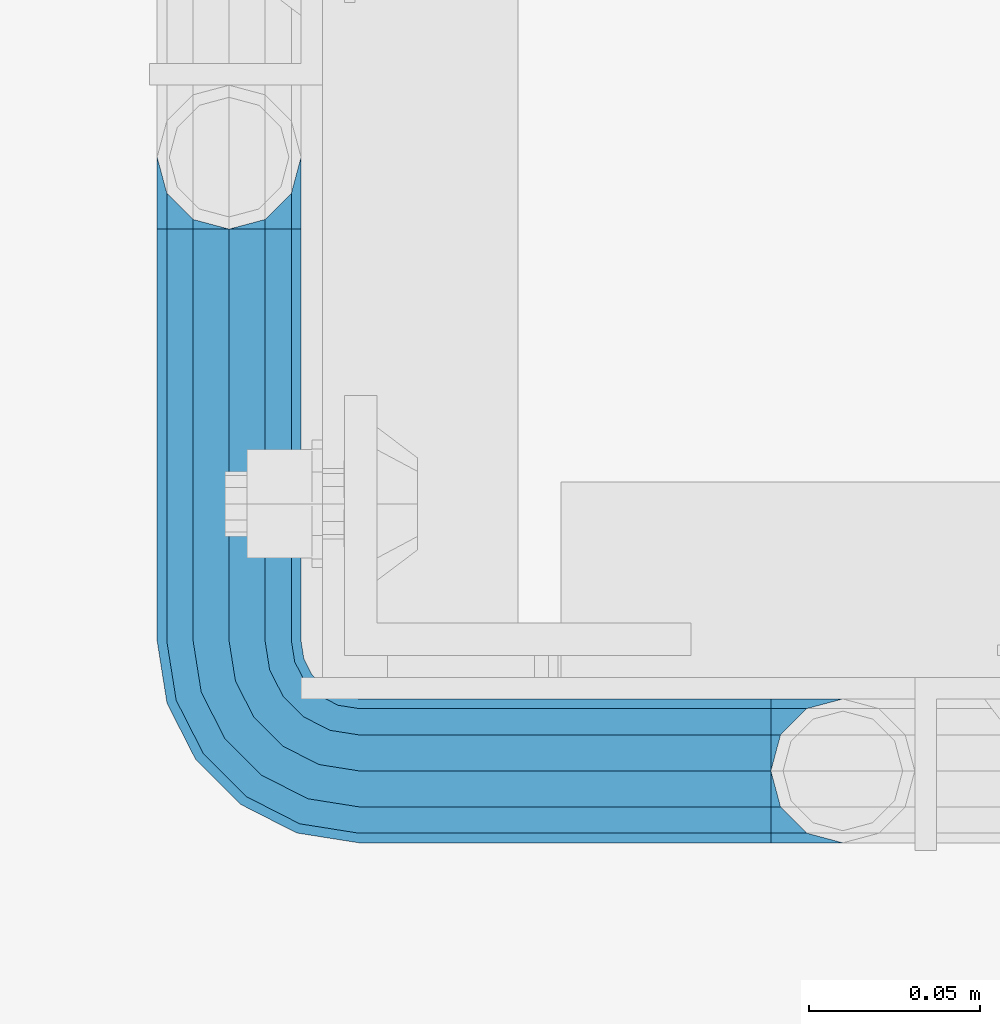
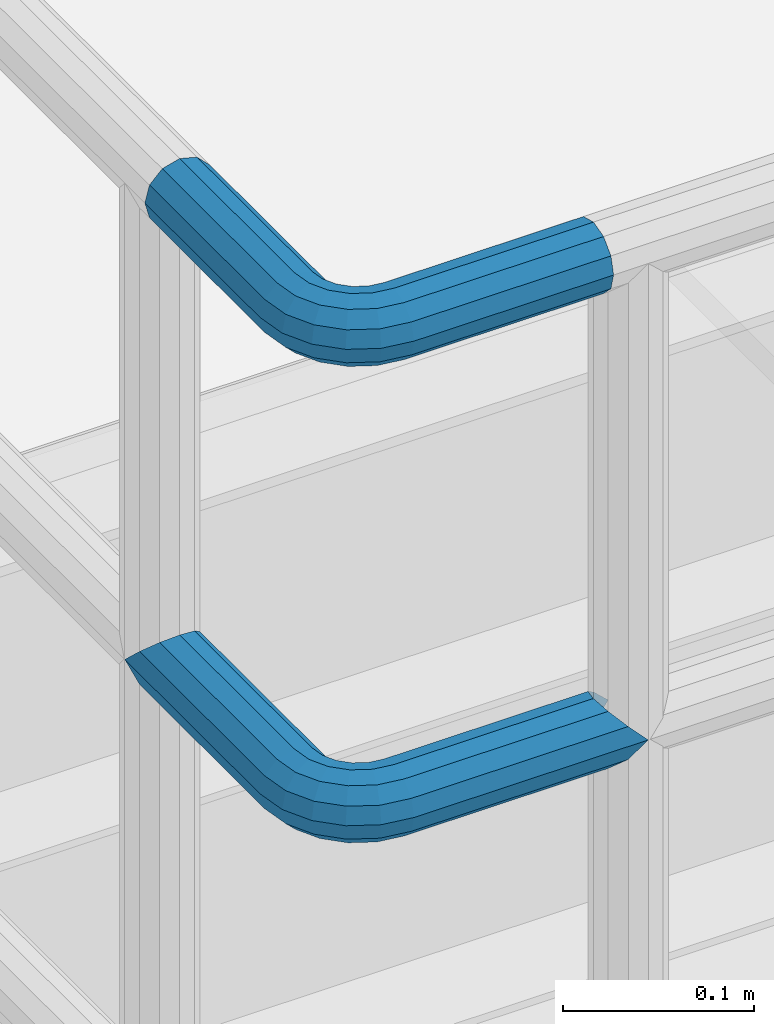
# One storey, part 1108 of 1876: 2 beams, 1 element without a shape of its own.
"""IFC2X3 building model written with IfcOpenShell, lengths in millimetres."""

from ifc_helpers import new_model, si_unit, frame, origin_with_axes, place, context, subcontext, project, spatial, faceted_brep, material, type_object, element, aggregate, save


model = new_model("IFC2X3")

# Units and contexts
model_context = context("Model", 3, precision=1e-05, world=origin_with_axes())
body_context = subcontext(model_context, "Body", "Model", "MODEL_VIEW")
ifc_project = project(units=[si_unit("LENGTHUNIT", "METRE", prefix="MILLI"), si_unit("AREAUNIT", "SQUARE_METRE"), si_unit("VOLUMEUNIT", "CUBIC_METRE"), si_unit("MASSUNIT", "GRAM", prefix="KILO"), si_unit("TIMEUNIT", "SECOND"), si_unit("PLANEANGLEUNIT", "RADIAN"), si_unit("SOLIDANGLEUNIT", "STERADIAN"), si_unit("THERMODYNAMICTEMPERATUREUNIT", "DEGREE_CELSIUS"), si_unit("LUMINOUSINTENSITYUNIT", "LUMEN")], contexts=[model_context])

# Site, building, storey
site_placement = place(None, origin_with_axes())
site = spatial("IfcSite", under=ifc_project, at=site_placement, CompositionType="ELEMENT")
building_placement = place(site_placement, origin_with_axes())
building = spatial("IfcBuilding", under=site, at=building_placement, Name="Undefined", CompositionType="ELEMENT")
storey_placement = place(building_placement, origin_with_axes())
storey = spatial("IfcBuildingStorey", under=building, at=storey_placement, Name="Undefined", CompositionType="ELEMENT", Elevation=0.0)

# Assembly, beams
assembly_placement = place(storey_placement, origin_with_axes())
assembly = element("IfcElementAssembly", 1, at=assembly_placement, inside=storey, Name="HANDRAIL", AssemblyPlace="NOTDEFINED", PredefinedType="RIGID_FRAME")
ifc_material = material()
beam_type = type_object("IfcBeamType", Name="PIPE1-1/4STD", PredefinedType="NOTDEFINED")
beam_1_placement = place(assembly_placement, frame((3338.07274593762, -11201.3643554687, 8785.225), z_axis=(0.0, 0.0, -1.0), x_axis=(0.0, -1.0, 0.0)))
beam_1 = element("IfcBeam", 2, at=beam_1_placement, type_object=beam_type, material=ifc_material, Name="HANDRAIL", ObjectType="PIPE1-1/4STD", context=body_context, shape_type="Brep", body=[
    faceted_brep([(9.09494701772928e-13, 21.0820000000003, 0.0), (10.5409999957128, 18.2575475579433, -10.5409999999993), (10.5409999999983, 18.2575475625836, 10.5410000000011), (10.5409999999983, -18.2575475625836, 10.5410000000011), (10.5409999957128, -18.2575475672238, -10.5409999999993), (9.09494701772928e-13, -21.0820000000003, 0.0), (18.2575475625817, -10.5410000000011, 18.2575475625836), (18.2575475625817, -10.5409999999974, 13.3999612267289), (13.6205863358537, -15.1779612267255, 8.76300000000083), (11.2725475625793, -17.5259999999998, 0.0), (13.6205863358537, -15.1779612267255, -8.76299999999901), (18.2575475625817, -10.5409999999974, -13.3999612267271), (18.2575475625817, -10.5410000000011, -18.2575475625836), (21.0819999999985, 0.0, -17.5259999999998), (21.0819999999985, 0.0, -21.0819999999985), (18.7339612267233, -8.76300000000083, -15.1779612267255), (18.7339612267251, 8.76299999999901, -15.1779612267255), (18.2575475625817, 10.5410000000011, -13.3999612267235), (18.2575475625817, 10.5409999999993, -18.2575475625836), (13.6205863358573, 15.1779612267255, -8.76299999999901), (11.2725475625839, 17.5259999999998, 0.0), (13.6205863358573, 15.1779612267255, 8.76300000000083), (18.2575475625817, 10.5410000000011, 13.3999612267253), (18.2575475625817, 10.5409999999993, 18.2575475625836), (18.7339612267251, 8.76299999999901, 15.1779612267273), (21.0819999999985, 1.81898940354586e-12, 17.5259999999998), (21.0819999999985, 1.81898940354586e-12, 21.0820000000003), (18.7339612267233, -8.76300000000083, 15.1779612267273), (141.7320022583, -8.7629999999981, 15.1779612267255), (141.7320022583, 1.81898940354586e-12, 17.525999999998), (153.505549272468, -1.86474665447258, 17.525999999998), (150.797633350759, -10.1988549067664, 15.1779612267237), (141.7320022583, -15.1779612267246, 8.76299999999901), (148.815301313444, -16.2998455832249, 8.76299999999901), (141.732002258301, -17.5259999999989, -1.81898940354586e-12), (148.08971742905, -18.5329631590612, -1.81898940354586e-12), (141.7320022583, -15.1779612267246, -8.76300000000083), (148.815301313443, -16.2998455832249, -8.76300000000083), (141.7320022583, -8.76299999999901, -15.1779612267273), (150.797633350759, -10.1988549067664, -15.1779612267273), (141.7320022583, 1.81898940354586e-12, -17.5260000000017), (153.505549272467, -1.86474665447258, -17.5260000000017), (141.7320022583, 8.76300000000174, -15.1779612267273), (156.213465194176, 6.46936159782217, -15.1779612267273), (141.7320022583, 15.1779612267273, -8.76300000000083), (158.195797231491, 12.5703522742806, -8.76300000000083), (141.7320022583, 17.5260000000017, -1.81898940354586e-12), (158.921381115884, 14.803469850116, -1.81898940354586e-12), (141.7320022583, 15.1779612267273, 8.76299999999901), (158.195797231491, 12.5703522742806, 8.76299999999901), (141.7320022583, 8.76300000000174, 15.1779612267255), (156.213465194176, 6.46936159782217, 15.1779612267237), (179.832000732422, -38.0999984741202, -17.5260000000017), (171.069000732422, -38.0999984741202, -15.1779612267273), (171.069000732422, -161.097989750122, -15.1779612267255), (179.832000732422, -158.7499511731, -17.5259999999998), (188.595000732423, -38.0999984741202, -15.1779612267273), (188.595000732422, -161.097990142627, -15.1779612267255), (169.291000732422, -38.0999984741202, -18.2575475625854), (179.832000732422, -38.0999984741202, -21.0820000000003), (179.832000732422, -158.7499511731, -21.0820000000003), (169.291000732422, -161.574403610517, -18.2575475625836), (161.574453169838, -38.0999984741193, -10.5410000000011), (161.574453169838, -169.2909511731, -10.5409999999993), (158.750000732422, -38.0999984741193, -1.81898940354586e-12), (158.750000732422, -179.831954956055, 0.0), (161.574453169838, -169.2909511731, 10.5409999999993), (161.574453169839, -38.0999984741193, 10.5409999999993), (169.291000732423, -38.0999984741193, 18.2575475625817), (169.291000732422, -161.574403610517, 18.2575475625836), (179.832000732423, -38.0999984741193, 21.0819999999985), (179.832000732422, -158.7499511731, 21.0820000000003), (141.7320022583, 10.5410000000011, 18.2575475625817), (141.7320022583, 18.2575475625854, 10.5409999999993), (141.7320022583, 21.0820000000012, -1.81898940354586e-12), (141.7320022583, 18.2575475625854, -10.5410000000011), (141.7320022583, 10.5410000000011, -18.2575475625854), (141.7320022583, 1.81898940354586e-12, -21.0820000000022), (141.7320022583, -10.5409999999983, -18.2575475625854), (141.7320022583, -18.2575475625817, -10.5410000000011), (141.732002258301, -21.0819999999985, -1.81898940354586e-12), (141.7320022583, -18.2575475625817, 10.5409999999993), (141.7320022583, -10.5409999999983, 18.2575475625817), (141.7320022583, 1.81898940354586e-12, 21.0819999999985), (153.505549272468, -1.86474665447258, 21.0819999999985), (156.762897410175, 8.16034008379484, 18.2575475625817), (159.147441744916, 15.4992129264911, 10.5409999999993), (160.020245547882, 18.1854268220623, -1.81898940354586e-12), (159.147441744916, 15.4992129264911, -10.5410000000011), (156.762897410174, 8.16034008379484, -18.2575475625854), (153.505549272467, -1.86474665447258, -21.0820000000022), (150.24820113476, -11.8898333927391, -18.2575475625854), (147.863656800018, -19.2287062354353, -10.5410000000011), (146.990852997053, -21.9149201310065, -1.81898940354586e-12), (147.863656800019, -19.2287062354362, 10.5409999999993), (150.248201134761, -11.8898333927391, 18.2575475625817), (157.930775129339, -15.8043003606008, 18.2575475625817), (164.126619473753, -7.27645222289357, 21.0819999999985), (153.395102273439, -22.0471184766338, 10.5409999999993), (151.734930784924, -24.332148498308, -1.81898940354586e-12), (153.395102273439, -22.0471184766338, -10.5410000000011), (157.930775129338, -15.8043003606008, -18.2575475625854), (164.126619473752, -7.27645222289357, -21.0820000000022), (170.322463818167, 1.25139591481275, -18.2575475625854), (174.858136674066, 7.49421403084671, -10.5410000000011), (176.518308162581, 9.77924405251997, -1.81898940354586e-12), (174.858136674067, 7.49421403084671, 10.5409999999993), (170.322463818167, 1.25139591481275, 18.2575475625817), (172.555548509522, -15.7053812586619, 21.0819999999985), (181.083396647228, -9.50953691424547, 18.2575475625817), (164.027700371817, -21.9012256030774, 18.2575475625817), (157.784882255784, -26.4368984589782, 10.5409999999993), (155.499852234111, -28.0970699474938, -1.81898940354586e-12), (157.784882255784, -26.4368984589782, -10.5410000000011), (164.027700371817, -21.9012256030774, -18.2575475625854), (172.555548509522, -15.7053812586619, -21.0820000000022), (181.083396647228, -9.50953691424547, -18.2575475625854), (187.32621476326, -4.97386405834459, -10.5410000000011), (189.611244784934, -3.31369256982998, -1.81898940354586e-12), (187.32621476326, -4.97386405834459, 10.5409999999993), (187.992340816218, -23.0691033222502, 18.2575475625817), (195.331213658914, -20.6845589875093, 10.5409999999993), (177.96725407795, -26.3264514599559, 21.0819999999985), (167.942167339683, -29.5837995976626, 18.2575475625817), (160.603294496986, -31.9683439324035, 10.5409999999993), (157.917080601415, -32.8411477353693, -1.81898940354586e-12), (160.603294496986, -31.9683439324035, -10.5410000000011), (167.942167339682, -29.5837995976635, -18.2575475625854), (177.96725407795, -26.3264514599568, -21.0820000000022), (187.992340816217, -23.0691033222511, -18.2575475625854), (195.331213658914, -20.6845589875093, -10.5410000000011), (198.017427554485, -19.8117551845444, -1.81898940354586e-12), (198.089548295007, -38.0999984741193, 10.5409999999993), (200.914000732423, -38.0999984741202, -1.81898940354586e-12), (190.373000732423, -38.0999984741193, 18.2575475625817), (190.373000732422, -38.0999984741202, -18.2575475625854), (198.089548295006, -38.0999984741202, -10.5410000000011), (200.913999999997, -179.831951173101, 0.0), (198.089548295005, -169.2909511731, -10.5409999999993), (190.373000732422, -161.574403610517, -18.2575475625836), (190.372999999998, -161.574403610517, -13.3999619591505), (169.290999999997, -161.574403610517, -13.3999604943019), (164.654039505696, -38.0999984741193, -8.76300000000083), (164.654039505696, -166.211364104819, -8.76300000000083), (162.306000732422, -38.0999984741193, -1.81898940354586e-12), (162.306000732422, -168.559402878092, 0.0), (164.654039505696, -166.211364104819, 8.76299999999901), (169.290999999997, -161.574403610517, 13.3999604943019), (164.654039505696, -38.0999984741193, 8.76299999999901), (171.069000732422, -38.0999984741193, 15.1779612267255), (171.069000732422, -161.097989750122, 15.1779612267255), (179.832000732422, -158.7499511731, 17.5259999999998), (179.832000732423, -38.0999984741193, 17.525999999998), (188.595000732423, -38.0999984741193, 15.1779612267255), (188.595000732422, -161.097990142627, 15.1779612267255), (197.358000732423, -38.0999984741202, -1.81898940354586e-12), (195.009961959149, -38.0999984741202, -8.76300000000083), (195.009961959148, -166.211365569668, -8.76300000000083), (197.358000732422, -168.559404342942, 0.0), (195.009961959149, -38.0999984741193, 8.76299999999901), (195.009961959148, -166.211365569668, 8.76299999999901), (190.372999999998, -161.574403610517, 13.3999619591505), (190.373000732422, -161.574403610517, 18.2575475625836), (198.089548295005, -169.2909511731, 10.5409999999993), (186.301362330245, -23.6185355382495, -15.1779612267273), (192.402353006703, -21.6362035009342, -8.76300000000083), (177.96725407795, -26.3264514599568, -17.5260000000017), (169.633145825655, -29.0343673816642, -15.1779612267273), (163.532155149196, -31.0166994189794, -8.76300000000083), (161.299037573361, -31.7422833033716, -1.81898940354586e-12), (163.532155149197, -31.0166994189785, 8.76299999999901), (169.633145825655, -29.0343673816642, 15.1779612267255), (177.96725407795, -26.3264514599568, 17.525999999998), (186.301362330245, -23.6185355382486, 15.1779612267255), (192.402353006703, -21.6362035009342, 8.76299999999901), (194.635470582539, -20.9106196165412, -1.81898940354586e-12), (184.834777081907, -6.78399948972401, -8.76300000000083), (186.734380352937, -5.40385692698237, -1.81898940354586e-12), (179.644964431229, -10.5546190928217, -15.1779612267273), (172.555548509522, -15.7053812586619, -17.5260000000017), (165.466132587815, -20.8561434245012, -15.1779612267273), (160.276319937137, -24.6267630275997, -8.76300000000083), (158.376716666108, -26.0069055903414, -1.81898940354586e-12), (160.276319937138, -24.6267630275997, 8.76299999999901), (165.466132587815, -20.8561434245012, 15.1779612267237), (172.555548509522, -15.7053812586619, 17.525999999998), (179.64496443123, -10.5546190928217, 15.1779612267237), (184.834777081907, -6.7839994897231, 8.76299999999901), (174.428143805429, 6.90237962052288, -1.81898940354586e-12), (173.048001242688, 5.00277634949271, 8.76299999999901), (173.048001242688, 5.00277634949271, -8.76300000000083), (169.277381639591, -0.187036301185799, -15.1779612267273), (164.126619473753, -7.27645222289357, -17.5260000000017), (158.975857307914, -14.3658681446022, -15.1779612267273), (155.205237704817, -19.5556807952798, -8.76300000000083), (153.825095142076, -21.45528406631, -1.81898940354586e-12), (155.205237704817, -19.5556807952798, 8.76299999999901), (158.975857307914, -14.3658681446022, 15.1779612267237), (164.126619473753, -7.27645222289357, 17.525999999998), (169.277381639591, -0.187036301185799, 15.1779612267237)], [[[0, 1, 2]], [[3, 4, 5]], [[6, 7, 8, 9, 10, 11, 12, 4, 3]], [[13, 14, 12, 11, 15]], [[16, 17, 18, 14, 13]], [[2, 1, 18, 17, 19, 20, 21, 22, 23]], [[23, 22, 24, 25, 26]], [[26, 25, 27, 7, 6]], [[28, 29, 30, 31]], [[32, 28, 31, 33]], [[34, 32, 33, 35]], [[36, 34, 35, 37]], [[38, 36, 37, 39]], [[40, 38, 39, 41]], [[42, 40, 41, 43]], [[44, 42, 43, 45]], [[46, 44, 45, 47]], [[48, 46, 47, 49]], [[50, 48, 49, 51]], [[52, 53, 54, 55]], [[56, 52, 55, 57]], [[58, 59, 60, 61]], [[62, 58, 61, 63]], [[64, 62, 63, 65]], [[65, 63, 66]], [[67, 64, 65, 66]], [[68, 67, 66, 69]], [[70, 68, 69, 71]], [[72, 73, 2, 23]], [[73, 74, 0, 2]], [[74, 75, 1, 0]], [[75, 76, 18, 1]], [[76, 77, 14, 18]], [[77, 78, 12, 14]], [[78, 79, 4, 12]], [[79, 80, 5, 4]], [[80, 81, 3, 5]], [[81, 82, 6, 3]], [[82, 83, 26, 6]], [[83, 72, 23, 26]], [[72, 83, 84, 85]], [[73, 72, 85, 86]], [[74, 73, 86, 87]], [[75, 74, 87, 88]], [[76, 75, 88, 89]], [[77, 76, 89, 90]], [[78, 77, 90, 91]], [[79, 78, 91, 92]], [[80, 79, 92, 93]], [[81, 80, 93, 94]], [[82, 81, 94, 95]], [[83, 82, 95, 84]], [[95, 96, 97, 84]], [[94, 98, 96, 95]], [[93, 99, 98, 94]], [[92, 100, 99, 93]], [[91, 101, 100, 92]], [[90, 102, 101, 91]], [[89, 103, 102, 90]], [[88, 104, 103, 89]], [[87, 105, 104, 88]], [[86, 106, 105, 87]], [[85, 107, 106, 86]], [[84, 97, 107, 85]], [[97, 108, 109, 107]], [[96, 110, 108, 97]], [[98, 111, 110, 96]], [[99, 112, 111, 98]], [[100, 113, 112, 99]], [[101, 114, 113, 100]], [[102, 115, 114, 101]], [[103, 116, 115, 102]], [[104, 117, 116, 103]], [[105, 118, 117, 104]], [[106, 119, 118, 105]], [[107, 109, 119, 106]], [[109, 120, 121, 119]], [[108, 122, 120, 109]], [[110, 123, 122, 108]], [[111, 124, 123, 110]], [[112, 125, 124, 111]], [[113, 126, 125, 112]], [[114, 127, 126, 113]], [[115, 128, 127, 114]], [[116, 129, 128, 115]], [[117, 130, 129, 116]], [[118, 131, 130, 117]], [[119, 121, 131, 118]], [[121, 132, 133, 131]], [[120, 134, 132, 121]], [[122, 70, 134, 120]], [[123, 68, 70, 122]], [[124, 67, 68, 123]], [[125, 64, 67, 124]], [[126, 62, 64, 125]], [[127, 58, 62, 126]], [[128, 59, 58, 127]], [[129, 135, 59, 128]], [[130, 136, 135, 129]], [[131, 133, 136, 130]], [[136, 133, 137, 138]], [[135, 136, 138, 139]], [[59, 135, 139, 60]], [[57, 55, 60, 139, 140]], [[54, 141, 61, 60, 55]], [[53, 142, 143, 141, 54]], [[142, 144, 145, 143]], [[66, 63, 61, 141, 143, 145, 146, 147, 69]], [[144, 148, 146, 145]], [[146, 148, 149, 150, 147]], [[69, 147, 150, 151, 71]], [[149, 152, 151, 150]], [[152, 153, 154, 151]], [[155, 156, 157, 158]], [[159, 155, 158, 160]], [[154, 153, 159, 160, 161]], [[71, 151, 154, 161, 162]], [[134, 70, 71, 162]], [[132, 134, 162, 163]], [[133, 132, 163, 137]], [[137, 163, 138]], [[162, 161, 160, 158, 157, 140, 139, 138, 163]], [[156, 56, 57, 140, 157]], [[164, 56, 156, 165]], [[166, 52, 56, 164]], [[167, 53, 52, 166]], [[168, 142, 53, 167]], [[169, 144, 142, 168]], [[170, 148, 144, 169]], [[171, 149, 148, 170]], [[172, 152, 149, 171]], [[173, 153, 152, 172]], [[174, 159, 153, 173]], [[175, 155, 159, 174]], [[165, 156, 155, 175]], [[176, 165, 175, 177]], [[178, 164, 165, 176]], [[179, 166, 164, 178]], [[180, 167, 166, 179]], [[181, 168, 167, 180]], [[182, 169, 168, 181]], [[183, 170, 169, 182]], [[184, 171, 170, 183]], [[185, 172, 171, 184]], [[186, 173, 172, 185]], [[187, 174, 173, 186]], [[177, 175, 174, 187]], [[188, 177, 187, 189]], [[190, 176, 177, 188]], [[191, 178, 176, 190]], [[192, 179, 178, 191]], [[193, 180, 179, 192]], [[194, 181, 180, 193]], [[195, 182, 181, 194]], [[196, 183, 182, 195]], [[197, 184, 183, 196]], [[198, 185, 184, 197]], [[199, 186, 185, 198]], [[189, 187, 186, 199]], [[49, 189, 199, 51]], [[47, 188, 189, 49]], [[45, 190, 188, 47]], [[43, 191, 190, 45]], [[41, 192, 191, 43]], [[39, 193, 192, 41]], [[37, 194, 193, 39]], [[35, 195, 194, 37]], [[33, 196, 195, 35]], [[31, 197, 196, 33]], [[30, 198, 197, 31]], [[51, 199, 198, 30]], [[29, 50, 51, 30]], [[50, 29, 25, 24]], [[21, 48, 50, 24, 22]], [[46, 48, 21, 20]], [[44, 46, 20, 19]], [[42, 44, 19, 17, 16]], [[40, 42, 16, 13]], [[38, 40, 13, 15]], [[10, 36, 38, 15, 11]], [[34, 36, 10, 9]], [[32, 34, 9, 8]], [[28, 32, 8, 7, 27]], [[29, 28, 27, 25]]]),
])
beam_2_placement = place(assembly_placement, frame((3338.07274593762, -11222.3987304687, 9090.025), z_axis=(0.0, 0.0, -1.0), x_axis=(0.0, -1.0, 0.0)))
beam_2 = element("IfcBeam", 3, at=beam_2_placement, type_object=beam_type, material=ifc_material, Name="HANDRAIL", ObjectType="PIPE1-1/4STD", context=body_context, shape_type="Brep", body=[
    faceted_brep([(9.09494701772928e-13, -21.0820000000003, 0.0), (0.0, -18.2575475625836, -10.5409999999993), (120.697624206543, -18.2575475625817, -10.5410000000011), (120.697624206543, -21.0819999999985, -1.81898940354586e-12), (0.0, -10.5410000000002, -18.2575475625836), (120.697624206543, -10.5409999999983, -18.2575475625854), (-4.28826751885936e-09, 0.0, -21.0820000000003), (120.697624206542, 1.81898940354586e-12, -21.0820000000022), (0.0, 10.5410000000002, -18.2575475625836), (120.697624206542, 10.5410000000011, -18.2575475625854), (0.0, 18.2575475625836, -10.5409999999993), (120.697624206542, 18.2575475625845, -10.5410000000011), (9.09494701772928e-13, 21.0820000000003, 0.0), (120.697624206542, 21.0820000000012, -1.81898940354586e-12), (0.0, 18.2575475625836, 10.5409999999993), (120.697624206543, 18.2575475625845, 10.5409999999993), (0.0, 10.5410000000002, 18.2575475625836), (120.697624206543, 10.5410000000011, 18.2575475625817), (0.0, 0.0, 21.0820000000003), (120.697624206543, 1.81898940354586e-12, 21.0819999999985), (0.0, -10.5410000000002, 18.2575475625836), (120.697624206543, -10.5409999999983, 18.2575475625817), (0.0, -18.2575475625836, 10.5409999999993), (120.697624206543, -18.2575475625817, 10.5409999999993), (0.0, -17.5259999999998, 0.0), (0.0, -15.1779612267264, 8.76300000000083), (120.697624206543, -15.1779612267246, 8.76299999999901), (120.697624206543, -17.5259999999989, -1.81898940354586e-12), (0.0, -8.76299999999992, 15.1779612267255), (120.697624206543, -8.76299999999901, 15.1779612267255), (0.0, 0.0, 17.5259999999998), (120.697624206543, 1.81898940354586e-12, 17.525999999998), (0.0, 8.76299999999992, 15.1779612267255), (120.697624206543, 8.76300000000174, 15.1779612267255), (0.0, 15.1779612267264, 8.76300000000083), (120.697624206543, 15.1779612267273, 8.76299999999901), (0.0, 17.5259999999998, 0.0), (120.697624206542, 17.5260000000017, -1.81898940354586e-12), (0.0, 15.1779612267264, -8.76300000000083), (120.697624206542, 15.1779612267273, -8.76300000000083), (0.0, 8.76299999999992, -15.1779612267255), (120.697624206542, 8.76300000000174, -15.1779612267273), (0.0, 0.0, -17.5259999999998), (120.697624206542, 1.81898940354586e-12, -17.5260000000017), (0.0, -8.76299999999992, -15.1779612267255), (120.697624206543, -8.76299999999901, -15.1779612267273), (0.0, -15.1779612267264, -8.76300000000083), (120.697624206543, -15.1779612267246, -8.76300000000083), (125.956474945295, -21.9149201310065, -1.81898940354586e-12), (126.829278748261, -19.2287062354353, 10.5409999999993), (129.213823083002, -11.8898333927391, 18.2575475625817), (132.471171220709, -1.86474665447258, 21.0819999999985), (135.728519358417, 8.16034008379484, 18.2575475625817), (138.113063693158, 15.4992129264911, 10.5409999999993), (138.985867496124, 18.1854268220613, -1.81898940354586e-12), (138.113063693158, 15.4992129264911, -10.5410000000011), (135.728519358416, 8.16034008379393, -18.2575475625854), (132.471171220709, -1.86474665447258, -21.0820000000022), (129.213823083002, -11.8898333927391, -18.2575475625854), (126.829278748261, -19.2287062354353, -10.5410000000011), (137.887003064126, 14.803469850116, -1.81898940354586e-12), (137.161419179733, 12.5703522742797, 8.76299999999901), (135.179087142418, 6.46936159782126, 15.1779612267237), (132.471171220709, -1.86474665447258, 17.525999999998), (129.763255299001, -10.1988549067664, 15.1779612267255), (127.780923261686, -16.2998455832249, 8.76299999999901), (127.055339377293, -18.5329631590612, -1.81898940354586e-12), (127.780923261686, -16.2998455832249, -8.76300000000083), (129.763255299001, -10.1988549067664, -15.1779612267273), (132.471171220709, -1.86474665447258, -17.5260000000017), (135.179087142417, 6.46936159782126, -15.1779612267273), (137.161419179733, 12.5703522742797, -8.76300000000083), (149.288085766415, 1.2513959148082, 18.2575475625817), (153.823758622315, 7.49421403084034, 10.5409999999993), (143.092241421999, -7.27645222289721, 21.0819999999985), (136.896397077584, -15.8043003606035, 18.2575475625817), (132.360724221684, -22.0471184766357, 10.5409999999993), (130.700552733168, -24.3321484983098, -1.81898940354586e-12), (132.360724221683, -22.0471184766357, -10.5410000000011), (136.896397077584, -15.8043003606035, -18.2575475625854), (143.092241421999, -7.27645222289811, -21.0820000000022), (149.288085766414, 1.2513959148082, -18.2575475625854), (153.823758622315, 7.49421403084034, -10.5410000000011), (155.48393011083, 9.77924405251451, -1.81898940354586e-12), (152.013623190936, 5.00277634948725, -8.76300000000083), (153.393765753678, 6.90237962051742, -1.81898940354586e-12), (148.243003587838, -0.187036301190346, -15.1779612267273), (143.092241421999, -7.27645222289721, -17.5260000000017), (137.94147925616, -14.365868144605, -15.1779612267273), (134.170859653062, -19.5556807952826, -8.76300000000083), (132.79071709032, -21.4552840663118, -1.81898940354586e-12), (134.170859653062, -19.5556807952826, 8.76299999999901), (137.94147925616, -14.365868144605, 15.1779612267255), (143.092241421999, -7.27645222289721, 17.525999999998), (148.243003587839, -0.187036301190346, 15.1779612267237), (152.013623190936, 5.00277634948725, 8.76299999999901), (160.04901859547, -9.50953691424547, 18.2575475625817), (166.291836711502, -4.9738640583455, 10.5409999999993), (151.521170457764, -15.7053812586619, 21.0819999999985), (142.993322320059, -21.9012256030783, 18.2575475625817), (136.750504204027, -26.4368984589792, 10.5409999999993), (134.465474182353, -28.0970699474938, -1.81898940354586e-12), (136.750504204027, -26.4368984589792, -10.5410000000011), (142.993322320058, -21.9012256030783, -18.2575475625854), (151.521170457764, -15.7053812586619, -21.0820000000022), (160.04901859547, -9.50953691424638, -18.2575475625854), (166.291836711502, -4.9738640583455, -10.5410000000011), (168.576866733175, -3.31369256982998, -1.81898940354586e-12), (163.800399030148, -6.78399948972401, -8.76300000000083), (165.700002301178, -5.40385692698237, -1.81898940354586e-12), (158.610586379471, -10.5546190928226, -15.1779612267273), (151.521170457764, -15.7053812586619, -17.5260000000017), (144.431754536057, -20.8561434245021, -15.1779612267273), (139.24194188538, -24.6267630275997, -8.76300000000083), (137.34233861435, -26.0069055903414, -1.81898940354586e-12), (139.24194188538, -24.6267630275997, 8.76299999999901), (144.431754536057, -20.8561434245021, 15.1779612267255), (151.521170457764, -15.7053812586619, 17.525999999998), (158.610586379471, -10.5546190928217, 15.1779612267255), (163.800399030148, -6.78399948972401, 8.76299999999901), (166.957962764459, -23.0691033222502, 18.2575475625817), (174.296835607155, -20.6845589875093, 10.5409999999993), (156.932876026191, -26.3264514599568, 21.0819999999985), (146.907789287925, -29.5837995976626, 18.2575475625817), (139.568916445228, -31.9683439324035, 10.5409999999993), (136.882702549657, -32.8411477353693, -1.81898940354586e-12), (139.568916445228, -31.9683439324044, -10.5410000000011), (146.907789287924, -29.5837995976635, -18.2575475625854), (156.932876026191, -26.3264514599568, -21.0820000000022), (166.957962764458, -23.0691033222502, -18.2575475625854), (174.296835607155, -20.6845589875093, -10.5410000000011), (176.983049502726, -19.8117551845444, -1.81898940354586e-12), (171.367974954944, -21.6362035009342, -8.76300000000083), (173.60109253078, -20.9106196165412, -1.81898940354586e-12), (165.266984278486, -23.6185355382495, -15.1779612267273), (156.932876026191, -26.3264514599568, -17.5260000000017), (148.598767773897, -29.0343673816642, -15.1779612267273), (142.497777097438, -31.0166994189794, -8.76300000000083), (140.264659521603, -31.7422833033725, -1.81898940354586e-12), (142.497777097438, -31.0166994189794, 8.76299999999901), (148.598767773897, -29.0343673816642, 15.1779612267255), (156.932876026191, -26.3264514599568, 17.525999999998), (165.266984278486, -23.6185355382486, 15.1779612267255), (171.367974954945, -21.6362035009342, 8.76299999999901), (148.256622680664, -38.0999984741202, -18.2575475625854), (140.54007511808, -38.0999984741202, -10.5410000000011), (158.797622680664, -38.0999984741202, -21.0820000000003), (169.338622680664, -38.0999984741202, -18.2575475625854), (177.055170243248, -38.0999984741202, -10.5410000000011), (179.879622680664, -38.0999984741193, -1.81898940354586e-12), (177.055170243248, -38.0999984741193, 10.5409999999993), (169.338622680664, -38.0999984741193, 18.2575475625817), (158.797622680665, -38.0999984741193, 21.0819999999985), (148.256622680664, -38.0999984741193, 18.2575475625817), (140.540075118081, -38.0999984741193, 10.5409999999993), (137.715622680664, -38.0999984741193, -1.81898940354586e-12), (173.975583907391, -38.0999984741202, -8.76300000000083), (176.323622680664, -38.0999984741193, -1.81898940354586e-12), (167.560622680664, -38.0999984741202, -15.1779612267273), (158.797622680664, -38.0999984741202, -17.5260000000017), (150.034622680664, -38.0999984741202, -15.1779612267273), (143.619661453938, -38.0999984741202, -8.76300000000083), (141.271622680664, -38.0999984741193, -1.81898940354586e-12), (143.619661453938, -38.0999984741193, 8.76299999999901), (150.034622680665, -38.0999984741193, 15.1779612267255), (158.797622680665, -38.0999984741193, 17.525999999998), (167.560622680664, -38.0999984741193, 15.1779612267255), (173.975583907391, -38.0999984741193, 8.76299999999901), (140.54007511808, -158.797576904297, -10.5409999999993), (137.715622680664, -158.797576904297, 0.0), (148.256622680664, -158.797576904297, -18.2575475625836), (158.797622680664, -158.797576904297, -21.0820000000003), (169.338622680664, -158.797576904297, -18.2575475625836), (177.055170243248, -158.797576904297, -10.5409999999993), (179.879622680664, -158.797576904297, 0.0), (177.055170243248, -158.797576904297, 10.5409999999993), (169.338622680664, -158.797576904297, 18.2575475625836), (158.797622680664, -158.797576904297, 21.0820000000003), (148.256622680664, -158.797576904297, 18.2575475625836), (140.54007511808, -158.797576904297, 10.5409999999993), (143.619661453938, -158.797576904297, 8.76300000000083), (141.271622680664, -158.797576904297, 0.0), (150.034622680664, -158.797576904297, 15.1779612267255), (158.797622680664, -158.797576904297, 17.5259999999998), (167.560622680664, -158.797576904297, 15.1779612267255), (173.97558390739, -158.797576904297, 8.76300000000083), (176.323622680664, -158.797576904297, 0.0), (173.97558390739, -158.797576904297, -8.76300000000083), (167.560622680664, -158.797576904297, -15.1779612267255), (158.797622680664, -158.797576904297, -17.5259999999998), (150.034622680664, -158.797576904297, -15.1779612267255), (143.619661453938, -158.797576904297, -8.76300000000083)], [[[0, 1, 2, 3]], [[1, 4, 5, 2]], [[4, 6, 7, 5]], [[6, 8, 9, 7]], [[8, 10, 11, 9]], [[10, 12, 13, 11]], [[12, 14, 15, 13]], [[14, 16, 17, 15]], [[16, 18, 19, 17]], [[18, 20, 21, 19]], [[20, 22, 23, 21]], [[22, 0, 3, 23]], [[24, 25, 26, 27]], [[25, 28, 29, 26]], [[28, 30, 31, 29]], [[30, 32, 33, 31]], [[32, 34, 35, 33]], [[34, 36, 37, 35]], [[36, 38, 39, 37]], [[38, 40, 41, 39]], [[40, 42, 43, 41]], [[42, 44, 45, 43]], [[44, 46, 47, 45]], [[46, 24, 27, 47]], [[22, 20, 18, 16, 14, 12, 10, 8, 6, 4, 1, 0], [46, 44, 42, 40, 38, 36, 34, 32, 30, 28, 25, 24]], [[23, 3, 48, 49]], [[21, 23, 49, 50]], [[19, 21, 50, 51]], [[17, 19, 51, 52]], [[15, 17, 52, 53]], [[13, 15, 53, 54]], [[11, 13, 54, 55]], [[9, 11, 55, 56]], [[7, 9, 56, 57]], [[5, 7, 57, 58]], [[2, 5, 58, 59]], [[3, 2, 59, 48]], [[35, 37, 60, 61]], [[33, 35, 61, 62]], [[31, 33, 62, 63]], [[29, 31, 63, 64]], [[26, 29, 64, 65]], [[27, 26, 65, 66]], [[47, 27, 66, 67]], [[45, 47, 67, 68]], [[43, 45, 68, 69]], [[41, 43, 69, 70]], [[39, 41, 70, 71]], [[37, 39, 71, 60]], [[52, 72, 73, 53]], [[51, 74, 72, 52]], [[50, 75, 74, 51]], [[49, 76, 75, 50]], [[48, 77, 76, 49]], [[59, 78, 77, 48]], [[58, 79, 78, 59]], [[57, 80, 79, 58]], [[56, 81, 80, 57]], [[55, 82, 81, 56]], [[54, 83, 82, 55]], [[53, 73, 83, 54]], [[71, 84, 85, 60]], [[70, 86, 84, 71]], [[69, 87, 86, 70]], [[68, 88, 87, 69]], [[67, 89, 88, 68]], [[66, 90, 89, 67]], [[65, 91, 90, 66]], [[64, 92, 91, 65]], [[63, 93, 92, 64]], [[62, 94, 93, 63]], [[61, 95, 94, 62]], [[60, 85, 95, 61]], [[72, 96, 97, 73]], [[74, 98, 96, 72]], [[75, 99, 98, 74]], [[76, 100, 99, 75]], [[77, 101, 100, 76]], [[78, 102, 101, 77]], [[79, 103, 102, 78]], [[80, 104, 103, 79]], [[81, 105, 104, 80]], [[82, 106, 105, 81]], [[83, 107, 106, 82]], [[73, 97, 107, 83]], [[84, 108, 109, 85]], [[86, 110, 108, 84]], [[87, 111, 110, 86]], [[88, 112, 111, 87]], [[89, 113, 112, 88]], [[90, 114, 113, 89]], [[91, 115, 114, 90]], [[92, 116, 115, 91]], [[93, 117, 116, 92]], [[94, 118, 117, 93]], [[95, 119, 118, 94]], [[85, 109, 119, 95]], [[96, 120, 121, 97]], [[98, 122, 120, 96]], [[99, 123, 122, 98]], [[100, 124, 123, 99]], [[101, 125, 124, 100]], [[102, 126, 125, 101]], [[103, 127, 126, 102]], [[104, 128, 127, 103]], [[105, 129, 128, 104]], [[106, 130, 129, 105]], [[107, 131, 130, 106]], [[97, 121, 131, 107]], [[108, 132, 133, 109]], [[110, 134, 132, 108]], [[111, 135, 134, 110]], [[112, 136, 135, 111]], [[113, 137, 136, 112]], [[114, 138, 137, 113]], [[115, 139, 138, 114]], [[116, 140, 139, 115]], [[117, 141, 140, 116]], [[118, 142, 141, 117]], [[119, 143, 142, 118]], [[109, 133, 143, 119]], [[127, 144, 145, 126]], [[128, 146, 144, 127]], [[129, 147, 146, 128]], [[130, 148, 147, 129]], [[131, 149, 148, 130]], [[121, 150, 149, 131]], [[120, 151, 150, 121]], [[122, 152, 151, 120]], [[123, 153, 152, 122]], [[124, 154, 153, 123]], [[125, 155, 154, 124]], [[126, 145, 155, 125]], [[132, 156, 157, 133]], [[134, 158, 156, 132]], [[135, 159, 158, 134]], [[136, 160, 159, 135]], [[137, 161, 160, 136]], [[138, 162, 161, 137]], [[139, 163, 162, 138]], [[140, 164, 163, 139]], [[141, 165, 164, 140]], [[142, 166, 165, 141]], [[143, 167, 166, 142]], [[133, 157, 167, 143]], [[155, 145, 168, 169]], [[145, 144, 170, 168]], [[144, 146, 171, 170]], [[146, 147, 172, 171]], [[147, 148, 173, 172]], [[148, 149, 174, 173]], [[149, 150, 175, 174]], [[150, 151, 176, 175]], [[151, 152, 177, 176]], [[152, 153, 178, 177]], [[153, 154, 179, 178]], [[154, 155, 169, 179]], [[162, 163, 180, 181]], [[163, 164, 182, 180]], [[164, 165, 183, 182]], [[165, 166, 184, 183]], [[166, 167, 185, 184]], [[167, 157, 186, 185]], [[157, 156, 187, 186]], [[156, 158, 188, 187]], [[158, 159, 189, 188]], [[159, 160, 190, 189]], [[160, 161, 191, 190]], [[161, 162, 181, 191]], [[170, 171, 172, 173, 174, 175, 176, 177, 178, 179, 169, 168], [182, 183, 184, 185, 186, 187, 188, 189, 190, 191, 181, 180]]]),
])
aggregate(assembly, [beam_1, beam_2])

save(model, "model.ifc")
